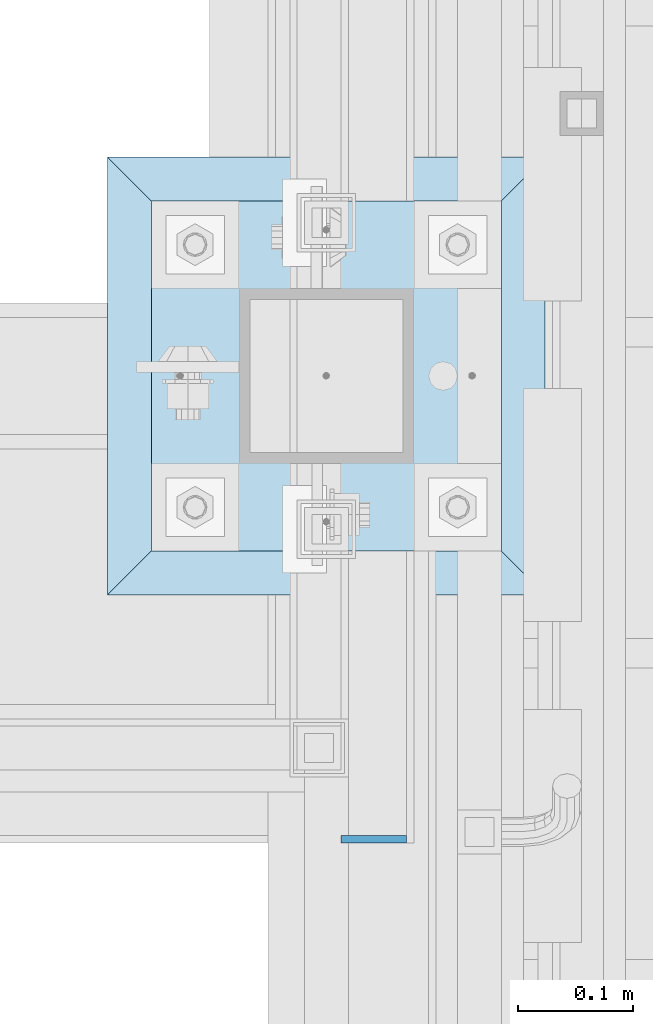
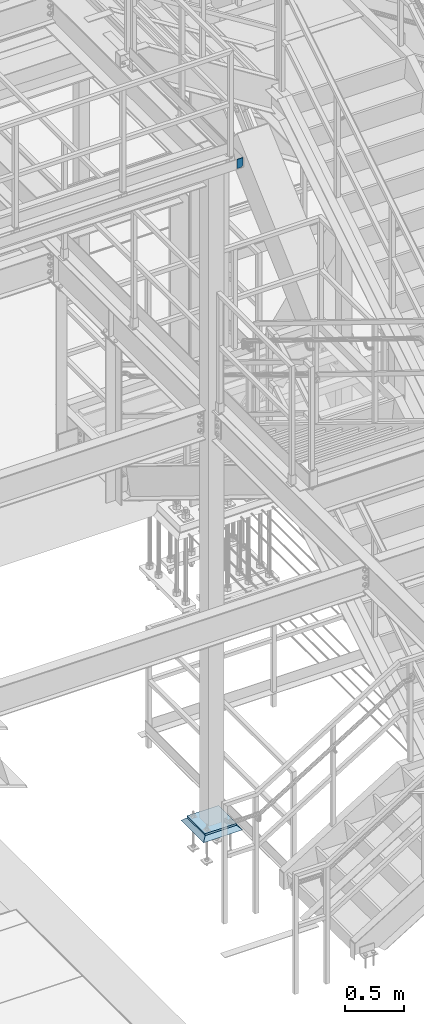
# One storey, part 3108 of 3843: 3 plates, 3 elements without a shape of their own.
"""IFC2X3 building model written with IfcOpenShell, lengths in millimetres."""

from ifc_helpers import new_model, si_unit, frame, origin_with_axes, place, context, subcontext, project, spatial, faceted_brep, material, type_object, element, aggregate, save


model = new_model("IFC2X3")

# Units and contexts
model_context = context("Model", 3, precision=1e-05, world=origin_with_axes())
body_context = subcontext(model_context, "Body", "Model", "MODEL_VIEW")
ifc_project = project(units=[si_unit("LENGTHUNIT", "METRE", prefix="MILLI"), si_unit("AREAUNIT", "SQUARE_METRE"), si_unit("VOLUMEUNIT", "CUBIC_METRE"), si_unit("MASSUNIT", "GRAM", prefix="KILO"), si_unit("TIMEUNIT", "SECOND"), si_unit("PLANEANGLEUNIT", "RADIAN"), si_unit("SOLIDANGLEUNIT", "STERADIAN"), si_unit("THERMODYNAMICTEMPERATUREUNIT", "DEGREE_CELSIUS"), si_unit("LUMINOUSINTENSITYUNIT", "LUMEN")], contexts=[model_context])

# Site, building, storey
site_placement = place(None, origin_with_axes())
site = spatial("IfcSite", under=ifc_project, at=site_placement, CompositionType="ELEMENT")
building_placement = place(site_placement, origin_with_axes())
building = spatial("IfcBuilding", under=site, at=building_placement, Name="Undefined", CompositionType="ELEMENT")
storey_placement = place(building_placement, origin_with_axes())
storey = spatial("IfcBuildingStorey", under=building, at=storey_placement, Name="Undefined", CompositionType="ELEMENT", Elevation=0.0)

# Assembly, plate
assembly_1_placement = place(storey_placement, origin_with_axes())
assembly_1 = element("IfcElementAssembly", 1, at=assembly_1_placement, inside=storey, Name="BEAM", AssemblyPlace="NOTDEFINED", PredefinedType="RIGID_FRAME")
ifc_material_1 = material(Name="STEEL/A572-50")
plate_type_1 = type_object("IfcPlateType", PredefinedType="NOTDEFINED")
plate_1_placement = place(assembly_1_placement, frame((53003.45, 19904.075, 37471.35), z_axis=(0.0, 0.0, 1.0), x_axis=(1.0, 0.0, 0.0)))
plate_1 = element("IfcPlate", 2, at=plate_1_placement, type_object=plate_type_1, material=ifc_material_1, Name="PLATE", context=body_context, shape_type="Brep", body=[
    faceted_brep([(0.0, -3.17499999999927, 0.0), (0.0, -3.17499999999927, 95.25), (-2.44140610448085e-05, 3.17500000000291, 95.2499999999927), (0.0, 3.17499999999927, 0.0), (57.1500015258789, -3.17499999999927, 95.25), (57.1500015258789, 3.17499999999927, 95.25), (57.1500015258789, -3.17499999999927, 19.0499992370605), (57.1500015258789, 3.17499999999927, 19.0499992370605), (38.1000000000131, -3.17500000000291, 0.0), (38.1000000000131, 3.17500000000291, 0.0)], [[[0, 1, 2, 3]], [[1, 4, 5, 2]], [[4, 6, 7, 5]], [[6, 8, 9, 7]], [[8, 0, 3, 9]], [[5, 7, 9, 3, 2]], [[8, 6, 4, 1, 0]]]),
])
aggregate(assembly_1, [plate_1])

assembly_2_placement = place(storey_placement, origin_with_axes())
assembly_2 = element("IfcElementAssembly", 3, at=assembly_2_placement, inside=storey, Name="GROUT", AssemblyPlace="NOTDEFINED", PredefinedType="REINFORCEMENT_UNIT")
ifc_material_2 = material(Name="CONCRETE/Concrete_Undefined")
plate_type_2 = type_object("IfcPlateType", PredefinedType="NOTDEFINED")
plate_2_placement = place(assembly_2_placement, frame((52800.25, 20116.8, 30499.05), z_axis=(0.0, 1.0, 0.0), x_axis=(1.0, 0.0, 0.0)))
plate_2 = element("IfcPlate", 4, at=plate_2_placement, type_object=plate_type_2, material=ifc_material_2, Name="GROUT", context=body_context, shape_type="Brep", body=[
    faceted_brep([(38.0999999997948, -19.0499999997846, 342.900000000212), (0.0, 19.0499999999993, 381.0), (0.0, 19.0500000000029, 0.0), (38.1000000006916, -19.0499999999811, 38.1000000006607), (342.90000000022, -19.0499999998137, 38.0999999997985), (381.0, 19.0499999999993, 0.0), (381.0, 19.0499999999993, 381.0), (342.90000000022, -19.0499999999811, 342.900000000212)], [[[0, 1, 2, 3]], [[4, 5, 6, 7]], [[4, 7, 0, 3]], [[5, 4, 3, 2]], [[6, 5, 2, 1]], [[7, 6, 1, 0]]]),
])
aggregate(assembly_2, [plate_2])

assembly_3_placement = place(storey_placement, origin_with_axes())
assembly_3 = element("IfcElementAssembly", 5, at=assembly_3_placement, inside=storey, Name="COLUMN", AssemblyPlace="NOTDEFINED", PredefinedType="RIGID_FRAME")
plate_type_3 = type_object("IfcPlateType", PredefinedType="NOTDEFINED")
plate_3_placement = place(assembly_3_placement, frame((52838.35, 20154.9, 30527.625), z_axis=(0.0, 1.0, 0.0), x_axis=(1.0, 0.0, 0.0)))
plate_3 = element("IfcPlate", 6, at=plate_3_placement, type_object=plate_type_3, material=ifc_material_1, Name="PLATE", context=body_context, shape_type="Brep", body=[
    faceted_brep([(0.0, -9.52500000000146, 0.0), (1.81898940354586e-12, -9.52500000000146, 304.800000000003), (1.81898940354586e-12, 9.52500000000146, 304.800000000003), (0.0, 9.52500000000146, 0.0), (304.799987792969, -9.52500000000146, 304.799987792969), (304.799987792969, 9.52500000000146, 304.799987792969), (304.799987792969, -9.52500000000146, 0.0), (304.799987792969, 9.52500000000146, 0.0)], [[[0, 1, 2, 3]], [[1, 4, 5, 2]], [[4, 6, 7, 5]], [[6, 0, 3, 7]], [[5, 7, 3, 2]], [[6, 4, 1, 0]]]),
])
aggregate(assembly_3, [plate_3])

save(model, "model.ifc")
